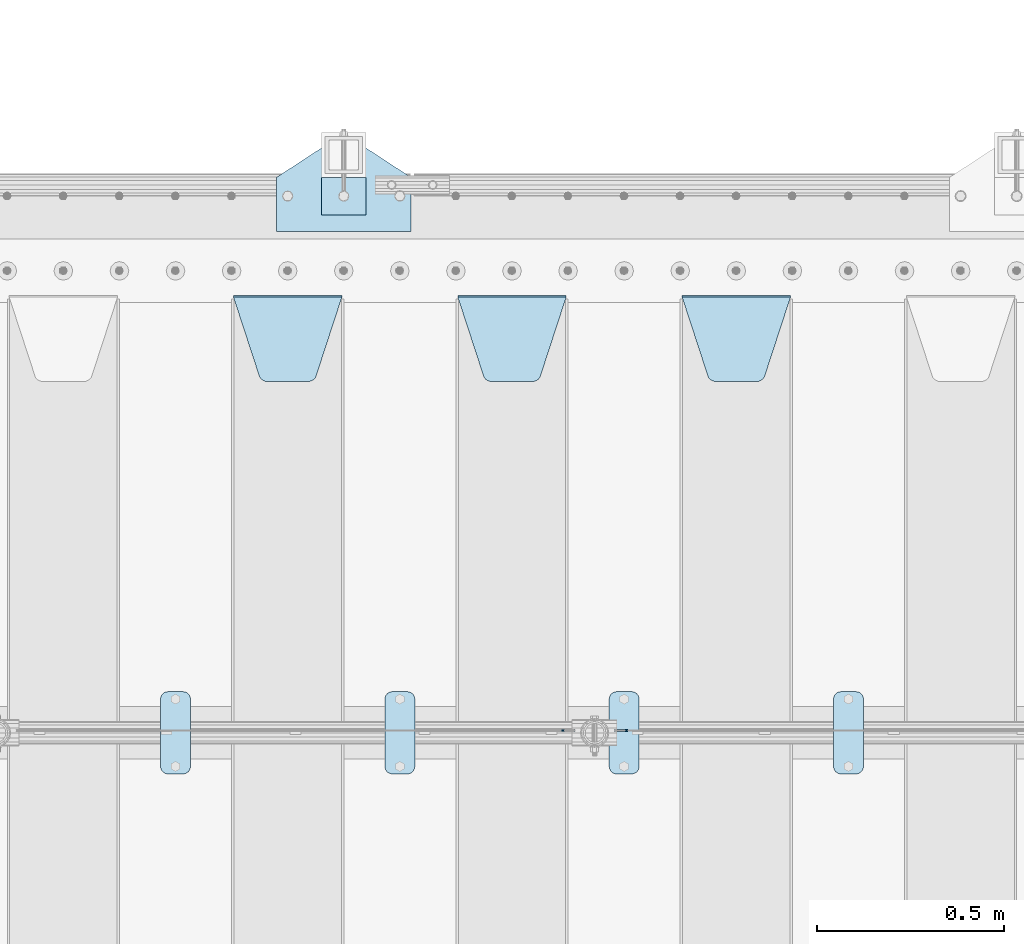
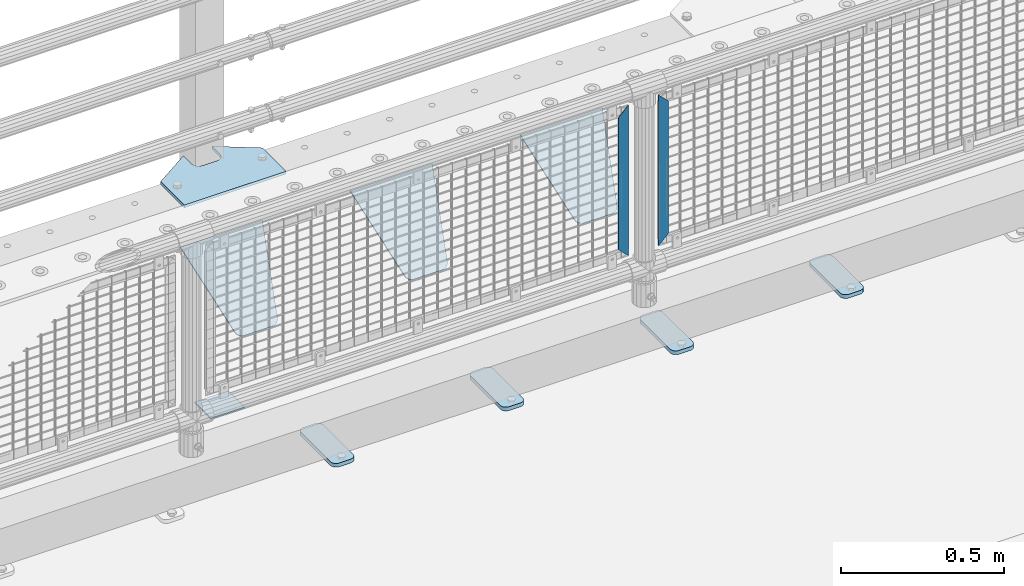
# One storey, part 218 of 247: 11 plates.
"""IFC2X3 building model written with IfcOpenShell, lengths in millimetres."""

from ifc_helpers import new_model, si_unit, frame, origin_with_axes, place, context, subcontext, project, spatial, faceted_brep, material, type_object, element, save


model = new_model("IFC2X3")

# Units and contexts
model_context = context("Model", 3, precision=1e-05, world=origin_with_axes())
body_context = subcontext(model_context, "Body", "Model", "MODEL_VIEW")
ifc_project = project(units=[si_unit("LENGTHUNIT", "METRE", prefix="MILLI"), si_unit("AREAUNIT", "SQUARE_METRE"), si_unit("VOLUMEUNIT", "CUBIC_METRE"), si_unit("MASSUNIT", "GRAM", prefix="KILO"), si_unit("TIMEUNIT", "SECOND"), si_unit("PLANEANGLEUNIT", "RADIAN"), si_unit("SOLIDANGLEUNIT", "STERADIAN"), si_unit("THERMODYNAMICTEMPERATUREUNIT", "DEGREE_CELSIUS"), si_unit("LUMINOUSINTENSITYUNIT", "LUMEN")], contexts=[model_context])

# Site, building, storey
site_placement = place(None, origin_with_axes())
site = spatial("IfcSite", under=ifc_project, at=site_placement, CompositionType="ELEMENT")
building_placement = place(site_placement, origin_with_axes())
building = spatial("IfcBuilding", under=site, at=building_placement, Name="Standard", CompositionType="ELEMENT")
storey_placement = place(building_placement, origin_with_axes())
storey = spatial("IfcBuildingStorey", under=building, at=storey_placement, Name="Undefined", CompositionType="ELEMENT", Elevation=0.0)

# Plates
ifc_material_1 = material(Name="STEEL/S355J2")
plate_type_1 = type_object("IfcPlateType", PredefinedType="NOTDEFINED")
plate_1_placement = place(storey_placement, frame((10860.0, 7774.5, 21.0199999999977), z_axis=(1.0, 0.0, 0.0), x_axis=(0.0, -0.999999999999548, -9.5100000000016e-07)))
element("IfcPlate", 1, at=plate_1_placement, inside=storey, type_object=plate_type_1, material=ifc_material_1, context=body_context, shape_type="Brep", body=[
    faceted_brep([(0.0, -7.0, 20.0), (0.0, -7.0, 60.0), (0.0, 7.0, 60.0), (0.0, 7.0, 20.0), (0.384294391935327, -7.0, 63.9018064403226), (0.384294391935327, 7.0, 63.9018064403226), (1.52240934977453, -7.0, 67.6536686473009), (1.52240934977453, 7.0, 67.6536686473009), (3.37060775394912, -7.0, 71.1114046603925), (3.37060775394912, 7.0, 71.1114046603925), (5.85786437626939, -7.0, 74.1421356237315), (5.85786437626939, 7.0, 74.1421356237315), (8.8885953396084, -7.0, 76.6293922460518), (8.8885953396084, 7.0, 76.6293922460518), (12.3463313526981, -7.0, 78.4775906502255), (12.3463313526981, 7.0, 78.4775906502255), (16.0981935596774, -7.0, 79.6157056080647), (16.0981935596774, 7.0, 79.6157056080647), (20.0, -7.0, 80.0), (20.0, 7.0, 80.0), (200.0, -7.0, 80.0), (200.0, 7.0, 80.0), (203.901806440323, -7.0, 79.6157056080647), (203.901806440323, 7.0, 79.6157056080647), (207.653668647302, -7.0, 78.4775906502255), (207.653668647302, 7.0, 78.4775906502255), (211.111404660392, -7.0, 76.6293922460518), (211.111404660392, 7.0, 76.6293922460518), (214.142135623731, -7.0, 74.1421356237315), (214.142135623731, 7.0, 74.1421356237315), (216.629392246051, -7.0, 71.1114046603925), (216.629392246051, 7.0, 71.1114046603925), (218.477590650225, -7.0, 67.6536686473009), (218.477590650225, 7.0, 67.6536686473009), (219.615705608065, -7.0, 63.9018064403226), (219.615705608065, 7.0, 63.9018064403226), (220.0, -7.0, 60.0), (220.0, 7.0, 60.0), (220.0, -7.0, 20.0), (220.0, 7.0, 20.0), (219.615705608065, -7.0, 16.0981935596774), (219.615705608065, 7.0, 16.0981935596774), (218.477590650225, -7.0, 12.3463313526991), (218.477590650225, 7.0, 12.3463313526991), (216.629392246051, -7.0, 8.88859533960749), (216.629392246051, 7.0, 8.88859533960749), (214.142135623731, -7.0, 5.85786437626848), (214.142135623731, 7.0, 5.85786437626848), (211.111404660392, -7.0, 3.37060775394821), (211.111404660392, 7.0, 3.37060775394821), (207.653668647302, -7.0, 1.52240934977453), (207.653668647302, 7.0, 1.52240934977453), (203.901806440323, -7.0, 0.384294391935327), (203.901806440323, 7.0, 0.384294391935327), (200.0, -7.0, 0.0), (200.0, 7.0, 0.0), (20.0, -7.0, 0.0), (20.0, 7.0, 0.0), (16.0981935596774, -7.0, 0.384294391935327), (16.0981935596774, 7.0, 0.384294391935327), (12.3463313526981, -7.0, 1.52240934977453), (12.3463313526981, 7.0, 1.52240934977453), (8.8885953396084, -7.0, 3.37060775394821), (8.8885953396084, 7.0, 3.37060775394821), (5.85786437626939, -7.0, 5.85786437626848), (5.85786437626939, 7.0, 5.85786437626848), (3.37060775394912, -7.0, 8.88859533960749), (3.37060775394912, 7.0, 8.88859533960749), (1.52240934977453, -7.0, 12.3463313526991), (1.52240934977453, 7.0, 12.3463313526991), (0.384294391935327, -7.0, 16.0981935596774), (0.384294391935327, 7.0, 16.0981935596774)], [[[0, 1, 2, 3]], [[1, 4, 5, 2]], [[4, 6, 7, 5]], [[6, 8, 9, 7]], [[8, 10, 11, 9]], [[10, 12, 13, 11]], [[12, 14, 15, 13]], [[14, 16, 17, 15]], [[16, 18, 19, 17]], [[18, 20, 21, 19]], [[20, 22, 23, 21]], [[22, 24, 25, 23]], [[24, 26, 27, 25]], [[26, 28, 29, 27]], [[28, 30, 31, 29]], [[30, 32, 33, 31]], [[32, 34, 35, 33]], [[34, 36, 37, 35]], [[36, 38, 39, 37]], [[38, 40, 41, 39]], [[40, 42, 43, 41]], [[42, 44, 45, 43]], [[44, 46, 47, 45]], [[46, 48, 49, 47]], [[48, 50, 51, 49]], [[50, 52, 53, 51]], [[52, 54, 55, 53]], [[54, 56, 57, 55]], [[56, 58, 59, 57]], [[58, 60, 61, 59]], [[60, 62, 63, 61]], [[62, 64, 65, 63]], [[64, 66, 67, 65]], [[66, 68, 69, 67]], [[68, 70, 71, 69]], [[70, 0, 3, 71]], [[5, 7, 9, 11, 13, 15, 17, 19, 21, 23, 25, 27, 29, 31, 33, 35, 37, 39, 41, 43, 45, 47, 49, 51, 53, 55, 57, 59, 61, 63, 65, 67, 69, 71, 3, 2]], [[70, 68, 66, 64, 62, 60, 58, 56, 54, 52, 50, 48, 46, 44, 42, 40, 38, 36, 34, 32, 30, 28, 26, 24, 22, 20, 18, 16, 14, 12, 10, 8, 6, 4, 1, 0]]]),
])
plate_2_placement = place(storey_placement, frame((10260.0, 7774.5, 21.0199999999977), z_axis=(1.0, 0.0, 0.0), x_axis=(0.0, -0.999999999999548, -9.5100000000016e-07)))
element("IfcPlate", 2, at=plate_2_placement, inside=storey, type_object=plate_type_1, material=ifc_material_1, context=body_context, shape_type="Brep", body=[
    faceted_brep([(0.0, -7.0, 20.0), (0.0, -7.0, 60.0), (0.0, 7.0, 60.0), (0.0, 7.0, 20.0), (0.384294391935327, -7.0, 63.9018064403226), (0.384294391935327, 7.0, 63.9018064403226), (1.52240934977453, -7.0, 67.6536686473009), (1.52240934977453, 7.0, 67.6536686473009), (3.37060775394912, -7.0, 71.1114046603925), (3.37060775394912, 7.0, 71.1114046603925), (5.85786437626939, -7.0, 74.1421356237315), (5.85786437626939, 7.0, 74.1421356237315), (8.8885953396084, -7.0, 76.6293922460518), (8.8885953396084, 7.0, 76.6293922460518), (12.3463313526981, -7.0, 78.4775906502255), (12.3463313526981, 7.0, 78.4775906502255), (16.0981935596774, -7.0, 79.6157056080647), (16.0981935596774, 7.0, 79.6157056080647), (20.0, -7.0, 80.0), (20.0, 7.0, 80.0), (200.0, -7.0, 80.0), (200.0, 7.0, 80.0), (203.901806440323, -7.0, 79.6157056080647), (203.901806440323, 7.0, 79.6157056080647), (207.653668647302, -7.0, 78.4775906502255), (207.653668647302, 7.0, 78.4775906502255), (211.111404660392, -7.0, 76.6293922460518), (211.111404660392, 7.0, 76.6293922460518), (214.142135623731, -7.0, 74.1421356237315), (214.142135623731, 7.0, 74.1421356237315), (216.629392246051, -7.0, 71.1114046603925), (216.629392246051, 7.0, 71.1114046603925), (218.477590650225, -7.0, 67.6536686473009), (218.477590650225, 7.0, 67.6536686473009), (219.615705608065, -7.0, 63.9018064403226), (219.615705608065, 7.0, 63.9018064403226), (220.0, -7.0, 60.0), (220.0, 7.0, 60.0), (220.0, -7.0, 20.0), (220.0, 7.0, 20.0), (219.615705608065, -7.0, 16.0981935596774), (219.615705608065, 7.0, 16.0981935596774), (218.477590650225, -7.0, 12.3463313526991), (218.477590650225, 7.0, 12.3463313526991), (216.629392246051, -7.0, 8.88859533960749), (216.629392246051, 7.0, 8.88859533960749), (214.142135623731, -7.0, 5.85786437626848), (214.142135623731, 7.0, 5.85786437626848), (211.111404660392, -7.0, 3.37060775394821), (211.111404660392, 7.0, 3.37060775394821), (207.653668647302, -7.0, 1.52240934977453), (207.653668647302, 7.0, 1.52240934977453), (203.901806440323, -7.0, 0.384294391935327), (203.901806440323, 7.0, 0.384294391935327), (200.0, -7.0, 0.0), (200.0, 7.0, 0.0), (20.0, -7.0, 0.0), (20.0, 7.0, 0.0), (16.0981935596774, -7.0, 0.384294391935327), (16.0981935596774, 7.0, 0.384294391935327), (12.3463313526981, -7.0, 1.52240934977453), (12.3463313526981, 7.0, 1.52240934977453), (8.8885953396084, -7.0, 3.37060775394821), (8.8885953396084, 7.0, 3.37060775394821), (5.85786437626939, -7.0, 5.85786437626848), (5.85786437626939, 7.0, 5.85786437626848), (3.37060775394912, -7.0, 8.88859533960749), (3.37060775394912, 7.0, 8.88859533960749), (1.52240934977453, -7.0, 12.3463313526991), (1.52240934977453, 7.0, 12.3463313526991), (0.384294391935327, -7.0, 16.0981935596774), (0.384294391935327, 7.0, 16.0981935596774)], [[[0, 1, 2, 3]], [[1, 4, 5, 2]], [[4, 6, 7, 5]], [[6, 8, 9, 7]], [[8, 10, 11, 9]], [[10, 12, 13, 11]], [[12, 14, 15, 13]], [[14, 16, 17, 15]], [[16, 18, 19, 17]], [[18, 20, 21, 19]], [[20, 22, 23, 21]], [[22, 24, 25, 23]], [[24, 26, 27, 25]], [[26, 28, 29, 27]], [[28, 30, 31, 29]], [[30, 32, 33, 31]], [[32, 34, 35, 33]], [[34, 36, 37, 35]], [[36, 38, 39, 37]], [[38, 40, 41, 39]], [[40, 42, 43, 41]], [[42, 44, 45, 43]], [[44, 46, 47, 45]], [[46, 48, 49, 47]], [[48, 50, 51, 49]], [[50, 52, 53, 51]], [[52, 54, 55, 53]], [[54, 56, 57, 55]], [[56, 58, 59, 57]], [[58, 60, 61, 59]], [[60, 62, 63, 61]], [[62, 64, 65, 63]], [[64, 66, 67, 65]], [[66, 68, 69, 67]], [[68, 70, 71, 69]], [[70, 0, 3, 71]], [[5, 7, 9, 11, 13, 15, 17, 19, 21, 23, 25, 27, 29, 31, 33, 35, 37, 39, 41, 43, 45, 47, 49, 51, 53, 55, 57, 59, 61, 63, 65, 67, 69, 71, 3, 2]], [[70, 68, 66, 64, 62, 60, 58, 56, 54, 52, 50, 48, 46, 44, 42, 40, 38, 36, 34, 32, 30, 28, 26, 24, 22, 20, 18, 16, 14, 12, 10, 8, 6, 4, 1, 0]]]),
])
plate_3_placement = place(storey_placement, frame((9660.0, 7774.5, 21.0199999999977), z_axis=(1.0, 0.0, 0.0), x_axis=(0.0, -0.999999999999548, -9.5100000000016e-07)))
element("IfcPlate", 3, at=plate_3_placement, inside=storey, type_object=plate_type_1, material=ifc_material_1, context=body_context, shape_type="Brep", body=[
    faceted_brep([(0.0, -7.0, 20.0), (0.0, -7.0, 60.0), (0.0, 7.0, 60.0), (0.0, 7.0, 20.0), (0.384294391935327, -7.0, 63.9018064403226), (0.384294391935327, 7.0, 63.9018064403226), (1.52240934977453, -7.0, 67.6536686473009), (1.52240934977453, 7.0, 67.6536686473009), (3.37060775394912, -7.0, 71.1114046603925), (3.37060775394912, 7.0, 71.1114046603925), (5.85786437626939, -7.0, 74.1421356237315), (5.85786437626939, 7.0, 74.1421356237315), (8.8885953396084, -7.0, 76.6293922460518), (8.8885953396084, 7.0, 76.6293922460518), (12.3463313526981, -7.0, 78.4775906502255), (12.3463313526981, 7.0, 78.4775906502255), (16.0981935596774, -7.0, 79.6157056080647), (16.0981935596774, 7.0, 79.6157056080647), (20.0, -7.0, 80.0), (20.0, 7.0, 80.0), (200.0, -7.0, 80.0), (200.0, 7.0, 80.0), (203.901806440323, -7.0, 79.6157056080647), (203.901806440323, 7.0, 79.6157056080647), (207.653668647302, -7.0, 78.4775906502255), (207.653668647302, 7.0, 78.4775906502255), (211.111404660392, -7.0, 76.6293922460518), (211.111404660392, 7.0, 76.6293922460518), (214.142135623731, -7.0, 74.1421356237315), (214.142135623731, 7.0, 74.1421356237315), (216.629392246051, -7.0, 71.1114046603925), (216.629392246051, 7.0, 71.1114046603925), (218.477590650225, -7.0, 67.6536686473009), (218.477590650225, 7.0, 67.6536686473009), (219.615705608065, -7.0, 63.9018064403226), (219.615705608065, 7.0, 63.9018064403226), (220.0, -7.0, 60.0), (220.0, 7.0, 60.0), (220.0, -7.0, 20.0), (220.0, 7.0, 20.0), (219.615705608065, -7.0, 16.0981935596774), (219.615705608065, 7.0, 16.0981935596774), (218.477590650225, -7.0, 12.3463313526991), (218.477590650225, 7.0, 12.3463313526991), (216.629392246051, -7.0, 8.88859533960749), (216.629392246051, 7.0, 8.88859533960749), (214.142135623731, -7.0, 5.85786437626848), (214.142135623731, 7.0, 5.85786437626848), (211.111404660392, -7.0, 3.37060775394821), (211.111404660392, 7.0, 3.37060775394821), (207.653668647302, -7.0, 1.52240934977453), (207.653668647302, 7.0, 1.52240934977453), (203.901806440323, -7.0, 0.384294391935327), (203.901806440323, 7.0, 0.384294391935327), (200.0, -7.0, 0.0), (200.0, 7.0, 0.0), (20.0, -7.0, 0.0), (20.0, 7.0, 0.0), (16.0981935596774, -7.0, 0.384294391935327), (16.0981935596774, 7.0, 0.384294391935327), (12.3463313526981, -7.0, 1.52240934977453), (12.3463313526981, 7.0, 1.52240934977453), (8.8885953396084, -7.0, 3.37060775394821), (8.8885953396084, 7.0, 3.37060775394821), (5.85786437626939, -7.0, 5.85786437626848), (5.85786437626939, 7.0, 5.85786437626848), (3.37060775394912, -7.0, 8.88859533960749), (3.37060775394912, 7.0, 8.88859533960749), (1.52240934977453, -7.0, 12.3463313526991), (1.52240934977453, 7.0, 12.3463313526991), (0.384294391935327, -7.0, 16.0981935596774), (0.384294391935327, 7.0, 16.0981935596774)], [[[0, 1, 2, 3]], [[1, 4, 5, 2]], [[4, 6, 7, 5]], [[6, 8, 9, 7]], [[8, 10, 11, 9]], [[10, 12, 13, 11]], [[12, 14, 15, 13]], [[14, 16, 17, 15]], [[16, 18, 19, 17]], [[18, 20, 21, 19]], [[20, 22, 23, 21]], [[22, 24, 25, 23]], [[24, 26, 27, 25]], [[26, 28, 29, 27]], [[28, 30, 31, 29]], [[30, 32, 33, 31]], [[32, 34, 35, 33]], [[34, 36, 37, 35]], [[36, 38, 39, 37]], [[38, 40, 41, 39]], [[40, 42, 43, 41]], [[42, 44, 45, 43]], [[44, 46, 47, 45]], [[46, 48, 49, 47]], [[48, 50, 51, 49]], [[50, 52, 53, 51]], [[52, 54, 55, 53]], [[54, 56, 57, 55]], [[56, 58, 59, 57]], [[58, 60, 61, 59]], [[60, 62, 63, 61]], [[62, 64, 65, 63]], [[64, 66, 67, 65]], [[66, 68, 69, 67]], [[68, 70, 71, 69]], [[70, 0, 3, 71]], [[5, 7, 9, 11, 13, 15, 17, 19, 21, 23, 25, 27, 29, 31, 33, 35, 37, 39, 41, 43, 45, 47, 49, 51, 53, 55, 57, 59, 61, 63, 65, 67, 69, 71, 3, 2]], [[70, 68, 66, 64, 62, 60, 58, 56, 54, 52, 50, 48, 46, 44, 42, 40, 38, 36, 34, 32, 30, 28, 26, 24, 22, 20, 18, 16, 14, 12, 10, 8, 6, 4, 1, 0]]]),
])
plate_4_placement = place(storey_placement, frame((9060.0, 7774.5, 21.0199999999977), z_axis=(1.0, 0.0, 0.0), x_axis=(0.0, -0.999999999999548, -9.5100000000016e-07)))
element("IfcPlate", 4, at=plate_4_placement, inside=storey, type_object=plate_type_1, material=ifc_material_1, context=body_context, shape_type="Brep", body=[
    faceted_brep([(0.0, -7.0, 20.0), (0.0, -7.0, 60.0), (0.0, 7.0, 60.0), (0.0, 7.0, 20.0), (0.384294391935327, -7.0, 63.9018064403226), (0.384294391935327, 7.0, 63.9018064403226), (1.52240934977453, -7.0, 67.6536686473009), (1.52240934977453, 7.0, 67.6536686473009), (3.37060775394912, -7.0, 71.1114046603925), (3.37060775394912, 7.0, 71.1114046603925), (5.85786437626939, -7.0, 74.1421356237315), (5.85786437626939, 7.0, 74.1421356237315), (8.8885953396084, -7.0, 76.6293922460518), (8.8885953396084, 7.0, 76.6293922460518), (12.3463313526981, -7.0, 78.4775906502255), (12.3463313526981, 7.0, 78.4775906502255), (16.0981935596774, -7.0, 79.6157056080647), (16.0981935596774, 7.0, 79.6157056080647), (20.0, -7.0, 80.0), (20.0, 7.0, 80.0), (200.0, -7.0, 80.0), (200.0, 7.0, 80.0), (203.901806440323, -7.0, 79.6157056080647), (203.901806440323, 7.0, 79.6157056080647), (207.653668647302, -7.0, 78.4775906502255), (207.653668647302, 7.0, 78.4775906502255), (211.111404660392, -7.0, 76.6293922460518), (211.111404660392, 7.0, 76.6293922460518), (214.142135623731, -7.0, 74.1421356237315), (214.142135623731, 7.0, 74.1421356237315), (216.629392246051, -7.0, 71.1114046603925), (216.629392246051, 7.0, 71.1114046603925), (218.477590650225, -7.0, 67.6536686473009), (218.477590650225, 7.0, 67.6536686473009), (219.615705608065, -7.0, 63.9018064403226), (219.615705608065, 7.0, 63.9018064403226), (220.0, -7.0, 60.0), (220.0, 7.0, 60.0), (220.0, -7.0, 20.0), (220.0, 7.0, 20.0), (219.615705608065, -7.0, 16.0981935596774), (219.615705608065, 7.0, 16.0981935596774), (218.477590650225, -7.0, 12.3463313526991), (218.477590650225, 7.0, 12.3463313526991), (216.629392246051, -7.0, 8.88859533960749), (216.629392246051, 7.0, 8.88859533960749), (214.142135623731, -7.0, 5.85786437626848), (214.142135623731, 7.0, 5.85786437626848), (211.111404660392, -7.0, 3.37060775394821), (211.111404660392, 7.0, 3.37060775394821), (207.653668647302, -7.0, 1.52240934977453), (207.653668647302, 7.0, 1.52240934977453), (203.901806440323, -7.0, 0.384294391935327), (203.901806440323, 7.0, 0.384294391935327), (200.0, -7.0, 0.0), (200.0, 7.0, 0.0), (20.0, -7.0, 0.0), (20.0, 7.0, 0.0), (16.0981935596774, -7.0, 0.384294391935327), (16.0981935596774, 7.0, 0.384294391935327), (12.3463313526981, -7.0, 1.52240934977453), (12.3463313526981, 7.0, 1.52240934977453), (8.8885953396084, -7.0, 3.37060775394821), (8.8885953396084, 7.0, 3.37060775394821), (5.85786437626939, -7.0, 5.85786437626848), (5.85786437626939, 7.0, 5.85786437626848), (3.37060775394912, -7.0, 8.88859533960749), (3.37060775394912, 7.0, 8.88859533960749), (1.52240934977453, -7.0, 12.3463313526991), (1.52240934977453, 7.0, 12.3463313526991), (0.384294391935327, -7.0, 16.0981935596774), (0.384294391935327, 7.0, 16.0981935596774)], [[[0, 1, 2, 3]], [[1, 4, 5, 2]], [[4, 6, 7, 5]], [[6, 8, 9, 7]], [[8, 10, 11, 9]], [[10, 12, 13, 11]], [[12, 14, 15, 13]], [[14, 16, 17, 15]], [[16, 18, 19, 17]], [[18, 20, 21, 19]], [[20, 22, 23, 21]], [[22, 24, 25, 23]], [[24, 26, 27, 25]], [[26, 28, 29, 27]], [[28, 30, 31, 29]], [[30, 32, 33, 31]], [[32, 34, 35, 33]], [[34, 36, 37, 35]], [[36, 38, 39, 37]], [[38, 40, 41, 39]], [[40, 42, 43, 41]], [[42, 44, 45, 43]], [[44, 46, 47, 45]], [[46, 48, 49, 47]], [[48, 50, 51, 49]], [[50, 52, 53, 51]], [[52, 54, 55, 53]], [[54, 56, 57, 55]], [[56, 58, 59, 57]], [[58, 60, 61, 59]], [[60, 62, 63, 61]], [[62, 64, 65, 63]], [[64, 66, 67, 65]], [[66, 68, 69, 67]], [[68, 70, 71, 69]], [[70, 0, 3, 71]], [[5, 7, 9, 11, 13, 15, 17, 19, 21, 23, 25, 27, 29, 31, 33, 35, 37, 39, 41, 43, 45, 47, 49, 51, 53, 55, 57, 59, 61, 63, 65, 67, 69, 71, 3, 2]], [[70, 68, 66, 64, 62, 60, 58, 56, 54, 52, 50, 48, 46, 44, 42, 40, 38, 36, 34, 32, 30, 28, 26, 24, 22, 20, 18, 16, 14, 12, 10, 8, 6, 4, 1, 0]]]),
])
ifc_material_2 = material(Name="STEEL/S355N")
plate_type_2 = type_object("IfcPlateType", PredefinedType="NOTDEFINED")
plate_5_placement = place(storey_placement, frame((10455.0, 8831.76776695594, -1.767766952965), z_axis=(0.0, -0.707106781186548, -0.707106781186547), x_axis=(1.0, 0.0, 0.0)))
element("IfcPlate", 5, at=plate_5_placement, inside=storey, type_object=plate_type_2, material=ifc_material_2, context=body_context, shape_type="Brep", body=[
    faceted_brep([(0.0, -2.49999999999909, 0.0), (69.345504679477, -2.5, 300.17173142483), (69.345504679477, 2.50000000000091, 300.171731424831), (0.0, 2.5, -9.09494701772928e-13), (70.9274061199576, -2.5, 304.897442415399), (70.9274061199576, 2.50000000000091, 304.8974424154), (73.3818627772307, -2.49999999999909, 309.234538108527), (73.3818627772307, 2.5, 309.234538108526), (76.6187032999551, -2.5, 313.023683126102), (76.6187032999551, 2.50000000000091, 313.023683126102), (80.5190132704993, -2.49999999999909, 316.125672595371), (80.5190132704993, 2.50000000000091, 316.125672595372), (84.9395038596849, -2.49999999999909, 318.426546230476), (84.9395038596849, 2.5, 318.426546230475), (89.7177759439219, -2.5, 319.841774983274), (89.7177759439219, 2.50000000000091, 319.841774983275), (94.678286292652, -2.5, 320.319366455077), (94.678286292652, 2.50000000000091, 320.319366455077), (195.321713707348, -2.5, 320.319366455077), (195.321713707348, 2.50000000000091, 320.319366455077), (200.282224056078, -2.5, 319.841774983274), (200.282224056078, 2.50000000000091, 319.841774983275), (205.060496140315, -2.5, 318.426546230475), (205.060496140315, 2.5, 318.426546230474), (209.480986729501, -2.49999999999818, 316.12567259537), (209.480986729501, 2.50000000000091, 316.12567259537), (213.381296700045, -2.5, 313.023683126101), (213.381296700045, 2.50000000000091, 313.023683126101), (216.618137222769, -2.5, 309.234538108525), (216.618137222769, 2.5, 309.234538108525), (219.072593880042, -2.49999999999909, 304.897442415398), (219.072593880042, 2.5, 304.897442415398), (220.654495320523, -2.5, 300.17173142483), (220.654495320523, 2.50000000000091, 300.171731424831), (290.0, -2.49999999999909, 0.0), (290.0, 2.5, -9.09494701772928e-13)], [[[0, 1, 2, 3]], [[1, 4, 5, 2]], [[4, 6, 7, 5]], [[6, 8, 9, 7]], [[8, 10, 11, 9]], [[10, 12, 13, 11]], [[12, 14, 15, 13]], [[14, 16, 17, 15]], [[16, 18, 19, 17]], [[18, 20, 21, 19]], [[20, 22, 23, 21]], [[22, 24, 25, 23]], [[24, 26, 27, 25]], [[26, 28, 29, 27]], [[28, 30, 31, 29]], [[30, 32, 33, 31]], [[32, 34, 35, 33]], [[34, 0, 3, 35]], [[5, 7, 9, 11, 13, 15, 17, 19, 21, 23, 25, 27, 29, 31, 33, 35, 3, 2]], [[34, 32, 30, 28, 26, 24, 22, 20, 18, 16, 14, 12, 10, 8, 6, 4, 1, 0]]]),
])
plate_6_placement = place(storey_placement, frame((9855.0, 8831.76776695594, -1.767766952965), z_axis=(0.0, -0.707106781186548, -0.707106781186547), x_axis=(1.0, 0.0, 0.0)))
element("IfcPlate", 6, at=plate_6_placement, inside=storey, type_object=plate_type_2, material=ifc_material_2, context=body_context, shape_type="Brep", body=[
    faceted_brep([(0.0, -2.49999999999909, 0.0), (69.345504679477, -2.5, 300.17173142483), (69.345504679477, 2.50000000000091, 300.171731424831), (0.0, 2.5, -9.09494701772928e-13), (70.9274061199576, -2.5, 304.897442415399), (70.9274061199576, 2.50000000000091, 304.8974424154), (73.3818627772307, -2.49999999999909, 309.234538108527), (73.3818627772307, 2.5, 309.234538108526), (76.6187032999551, -2.5, 313.023683126102), (76.6187032999551, 2.50000000000091, 313.023683126102), (80.5190132704993, -2.49999999999909, 316.125672595371), (80.5190132704993, 2.50000000000091, 316.125672595372), (84.9395038596849, -2.49999999999909, 318.426546230476), (84.9395038596849, 2.5, 318.426546230475), (89.7177759439219, -2.5, 319.841774983274), (89.7177759439219, 2.50000000000091, 319.841774983275), (94.678286292652, -2.5, 320.319366455077), (94.678286292652, 2.50000000000091, 320.319366455077), (195.321713707348, -2.5, 320.319366455077), (195.321713707348, 2.50000000000091, 320.319366455077), (200.282224056078, -2.5, 319.841774983274), (200.282224056078, 2.50000000000091, 319.841774983275), (205.060496140315, -2.5, 318.426546230475), (205.060496140315, 2.5, 318.426546230474), (209.480986729501, -2.49999999999818, 316.12567259537), (209.480986729501, 2.50000000000091, 316.12567259537), (213.381296700045, -2.5, 313.023683126101), (213.381296700045, 2.50000000000091, 313.023683126101), (216.618137222769, -2.5, 309.234538108525), (216.618137222769, 2.5, 309.234538108525), (219.072593880042, -2.49999999999909, 304.897442415398), (219.072593880042, 2.5, 304.897442415398), (220.654495320523, -2.5, 300.17173142483), (220.654495320523, 2.50000000000091, 300.171731424831), (290.0, -2.49999999999909, 0.0), (290.0, 2.5, -9.09494701772928e-13)], [[[0, 1, 2, 3]], [[1, 4, 5, 2]], [[4, 6, 7, 5]], [[6, 8, 9, 7]], [[8, 10, 11, 9]], [[10, 12, 13, 11]], [[12, 14, 15, 13]], [[14, 16, 17, 15]], [[16, 18, 19, 17]], [[18, 20, 21, 19]], [[20, 22, 23, 21]], [[22, 24, 25, 23]], [[24, 26, 27, 25]], [[26, 28, 29, 27]], [[28, 30, 31, 29]], [[30, 32, 33, 31]], [[32, 34, 35, 33]], [[34, 0, 3, 35]], [[5, 7, 9, 11, 13, 15, 17, 19, 21, 23, 25, 27, 29, 31, 33, 35, 3, 2]], [[34, 32, 30, 28, 26, 24, 22, 20, 18, 16, 14, 12, 10, 8, 6, 4, 1, 0]]]),
])
plate_7_placement = place(storey_placement, frame((9255.0, 8831.76776695594, -1.767766952965), z_axis=(0.0, -0.707106781186548, -0.707106781186547), x_axis=(1.0, 0.0, 0.0)))
element("IfcPlate", 7, at=plate_7_placement, inside=storey, type_object=plate_type_2, material=ifc_material_2, context=body_context, shape_type="Brep", body=[
    faceted_brep([(0.0, -2.49999999999909, 0.0), (69.345504679477, -2.5, 300.17173142483), (69.345504679477, 2.50000000000091, 300.171731424831), (0.0, 2.5, -9.09494701772928e-13), (70.9274061199576, -2.5, 304.897442415399), (70.9274061199576, 2.50000000000091, 304.8974424154), (73.3818627772307, -2.49999999999909, 309.234538108527), (73.3818627772307, 2.5, 309.234538108526), (76.6187032999551, -2.5, 313.023683126102), (76.6187032999551, 2.50000000000091, 313.023683126102), (80.5190132704993, -2.49999999999909, 316.125672595371), (80.5190132704993, 2.50000000000091, 316.125672595372), (84.9395038596849, -2.49999999999909, 318.426546230476), (84.9395038596849, 2.5, 318.426546230475), (89.7177759439219, -2.5, 319.841774983274), (89.7177759439219, 2.50000000000091, 319.841774983275), (94.678286292652, -2.5, 320.319366455077), (94.678286292652, 2.50000000000091, 320.319366455077), (195.321713707348, -2.5, 320.319366455077), (195.321713707348, 2.50000000000091, 320.319366455077), (200.282224056078, -2.5, 319.841774983274), (200.282224056078, 2.50000000000091, 319.841774983275), (205.060496140315, -2.5, 318.426546230475), (205.060496140315, 2.5, 318.426546230474), (209.480986729501, -2.49999999999818, 316.12567259537), (209.480986729501, 2.50000000000091, 316.12567259537), (213.381296700045, -2.5, 313.023683126101), (213.381296700045, 2.50000000000091, 313.023683126101), (216.618137222769, -2.5, 309.234538108525), (216.618137222769, 2.5, 309.234538108525), (219.072593880042, -2.49999999999909, 304.897442415398), (219.072593880042, 2.5, 304.897442415398), (220.654495320523, -2.5, 300.17173142483), (220.654495320523, 2.50000000000091, 300.171731424831), (290.0, -2.49999999999909, 0.0), (290.0, 2.5, -9.09494701772928e-13)], [[[0, 1, 2, 3]], [[1, 4, 5, 2]], [[4, 6, 7, 5]], [[6, 8, 9, 7]], [[8, 10, 11, 9]], [[10, 12, 13, 11]], [[12, 14, 15, 13]], [[14, 16, 17, 15]], [[16, 18, 19, 17]], [[18, 20, 21, 19]], [[20, 22, 23, 21]], [[22, 24, 25, 23]], [[24, 26, 27, 25]], [[26, 28, 29, 27]], [[28, 30, 31, 29]], [[30, 32, 33, 31]], [[32, 34, 35, 33]], [[34, 0, 3, 35]], [[5, 7, 9, 11, 13, 15, 17, 19, 21, 23, 25, 27, 29, 31, 33, 35, 3, 2]], [[34, 32, 30, 28, 26, 24, 22, 20, 18, 16, 14, 12, 10, 8, 6, 4, 1, 0]]]),
])
ifc_material_3 = material(Name="Misc_Undefined")
plate_type_3 = type_object("IfcPlateType", PredefinedType="NOTDEFINED")
plate_8_placement = place(storey_placement, frame((10309.509713541, 7670.5, 879.519963133601), z_axis=(-0.707008801899319, 0.0, -0.707204746899291), x_axis=(-0.707204746899294, 0.0, 0.707008801899315)))
element("IfcPlate", 8, at=plate_8_placement, inside=storey, type_object=plate_type_3, material=ifc_material_3, context=body_context, shape_type="Brep", body=[
    faceted_brep([(1.81898940354586e-12, -1.5, -5.6843418860808e-14), (-348.552185058596, -1.5, 348.655029296875), (-348.552185058596, 1.5, 348.655029296875), (1.81898940354586e-12, 1.5, -5.6843418860808e-14), (-348.544891357424, -1.5, 398.152496337891), (-348.544891357424, 1.5, 398.152496337891), (49.50439453125, -1.5, 7.6397554948926e-11), (49.50439453125, 1.5, 7.6397554948926e-11)], [[[0, 1, 2, 3]], [[1, 4, 5, 2]], [[4, 6, 7, 5]], [[6, 0, 3, 7]], [[5, 7, 3, 2]], [[6, 4, 1, 0]]]),
])
plate_9_placement = place(storey_placement, frame((10132.4996874836, 7670.5, 879.52), z_axis=(0.707103624179499, 0.0, -0.707109938179501), x_axis=(0.707109938179497, 0.0, 0.707103624179503)))
element("IfcPlate", 9, at=plate_9_placement, inside=storey, type_object=plate_type_3, material=ifc_material_3, context=body_context, shape_type="Brep", body=[
    faceted_brep([(1.81898940354586e-12, -1.5, -5.6843418860808e-14), (-348.605163574215, -1.5, 348.60208129883), (-348.605163574215, 1.5, 348.60208129883), (1.81898940354586e-12, 1.5, -5.6843418860808e-14), (-348.605163574215, -1.5, 398.099334716799), (-348.605163574215, 1.5, 398.099334716799), (49.4976959228497, -1.5, 7.09405867382884e-11), (49.4976959228497, 1.5, 7.09405867382884e-11)], [[[0, 1, 2, 3]], [[1, 4, 5, 2]], [[4, 6, 7, 5]], [[6, 0, 3, 7]], [[5, 7, 3, 2]], [[6, 4, 1, 0]]]),
])
plate_type_4 = type_object("IfcPlateType", PredefinedType="NOTDEFINED")
plate_10_placement = place(storey_placement, frame((9370.0, 9005.0, 5.00000000004911), z_axis=(0.0, 1.0, 0.0), x_axis=(1.0, 0.0, 0.0)))
element("IfcPlate", 10, at=plate_10_placement, inside=storey, type_object=plate_type_4, material=ifc_material_1, context=body_context, shape_type="Brep", body=[
    faceted_brep([(9.04219632502645e-09, -5.00000000143385, -2.89173840428703e-09), (2.31396552408114e-06, -5.0, 145.0), (2.31396552408114e-06, 5.0, 145.0), (7.66340235713869e-09, 4.99999999856618, -2.89173840428703e-09), (130.0, -5.0, 230.0), (130.0, 5.0, 230.0), (130.0, -5.0, 180.0), (130.0, 5.0, 180.0), (130.48036798992, -5.0, 175.122741949597), (130.48036798992, 5.0, 175.122741949597), (131.903011687218, -5.0, 170.432914190873), (131.903011687218, 5.0, 170.432914190873), (134.213259692437, -5.0, 166.11074417451), (134.213259692437, 5.0, 166.11074417451), (137.322330470337, -5.0, 162.322330470337), (137.322330470337, 5.0, 162.322330470337), (141.11074417451, -5.0, 159.213259692437), (141.11074417451, 5.0, 159.213259692437), (145.432914190873, -5.0, 156.903011687218), (145.432914190873, 5.0, 156.903011687218), (150.122741949597, -5.0, 155.48036798992), (150.122741949597, 5.0, 155.48036798992), (155.0, -5.0, 155.0), (155.0, 5.0, 155.0), (205.0, -5.0, 155.0), (205.0, 5.0, 155.0), (209.877258050403, -5.0, 155.48036798992), (209.877258050403, 5.0, 155.48036798992), (214.567085809127, -5.0, 156.903011687218), (214.567085809127, 5.0, 156.903011687218), (218.88925582549, -5.0, 159.213259692437), (218.88925582549, 5.0, 159.213259692437), (222.677669529663, -5.0, 162.322330470337), (222.677669529663, 5.0, 162.322330470337), (225.786740307563, -5.0, 166.11074417451), (225.786740307563, 5.0, 166.11074417451), (228.096988312782, -5.0, 170.432914190873), (228.096988312782, 5.0, 170.432914190873), (229.51963201008, -5.0, 175.122741949597), (229.51963201008, 5.0, 175.122741949597), (230.0, -5.0, 180.0), (230.0, 5.0, 180.0), (230.0, -5.0, 230.0), (230.0, 5.0, 230.0), (360.0, -5.0, 145.0), (360.0, 5.0, 145.0), (360.0, -5.0, -7.27595761418343e-12), (360.0, 5.0, -7.27595761418343e-12)], [[[0, 1, 2, 3]], [[1, 4, 5, 2]], [[4, 6, 7, 5]], [[6, 8, 9, 7]], [[8, 10, 11, 9]], [[10, 12, 13, 11]], [[12, 14, 15, 13]], [[14, 16, 17, 15]], [[16, 18, 19, 17]], [[18, 20, 21, 19]], [[20, 22, 23, 21]], [[22, 24, 25, 23]], [[24, 26, 27, 25]], [[26, 28, 29, 27]], [[28, 30, 31, 29]], [[30, 32, 33, 31]], [[32, 34, 35, 33]], [[34, 36, 37, 35]], [[36, 38, 39, 37]], [[38, 40, 41, 39]], [[40, 42, 43, 41]], [[42, 44, 45, 43]], [[44, 46, 47, 45]], [[46, 0, 3, 47]], [[5, 7, 9, 11, 13, 15, 17, 19, 21, 23, 25, 27, 29, 31, 33, 35, 37, 39, 41, 43, 45, 47, 3, 2]], [[46, 44, 42, 40, 38, 36, 34, 32, 30, 28, 26, 24, 22, 20, 18, 16, 14, 12, 10, 8, 6, 4, 1, 0]]]),
])
plate_type_5 = type_object("IfcPlateType", PredefinedType="NOTDEFINED")
plate_11_placement = place(storey_placement, frame((9490.00000000014, 9050.00000000021, -857.500000000002), z_axis=(0.0, 1.0, 0.0), x_axis=(1.0, 0.0, 0.0)))
element("IfcPlate", 11, at=plate_11_placement, inside=storey, type_object=plate_type_5, material=ifc_material_1, context=body_context, shape_type="Brep", body=[
    faceted_brep([(0.0, -2.49999999999909, 0.0), (0.0, -2.5, 100.0), (0.0, 2.5, 100.0), (0.0, 2.5, -9.09494701772928e-13), (120.0, -2.5, 100.0), (120.0, 2.5, 100.0), (120.0, -2.5, 0.0), (120.0, 2.5, 0.0)], [[[0, 1, 2, 3]], [[1, 4, 5, 2]], [[4, 6, 7, 5]], [[6, 0, 3, 7]], [[5, 7, 3, 2]], [[6, 4, 1, 0]]]),
])

save(model, "model.ifc")
